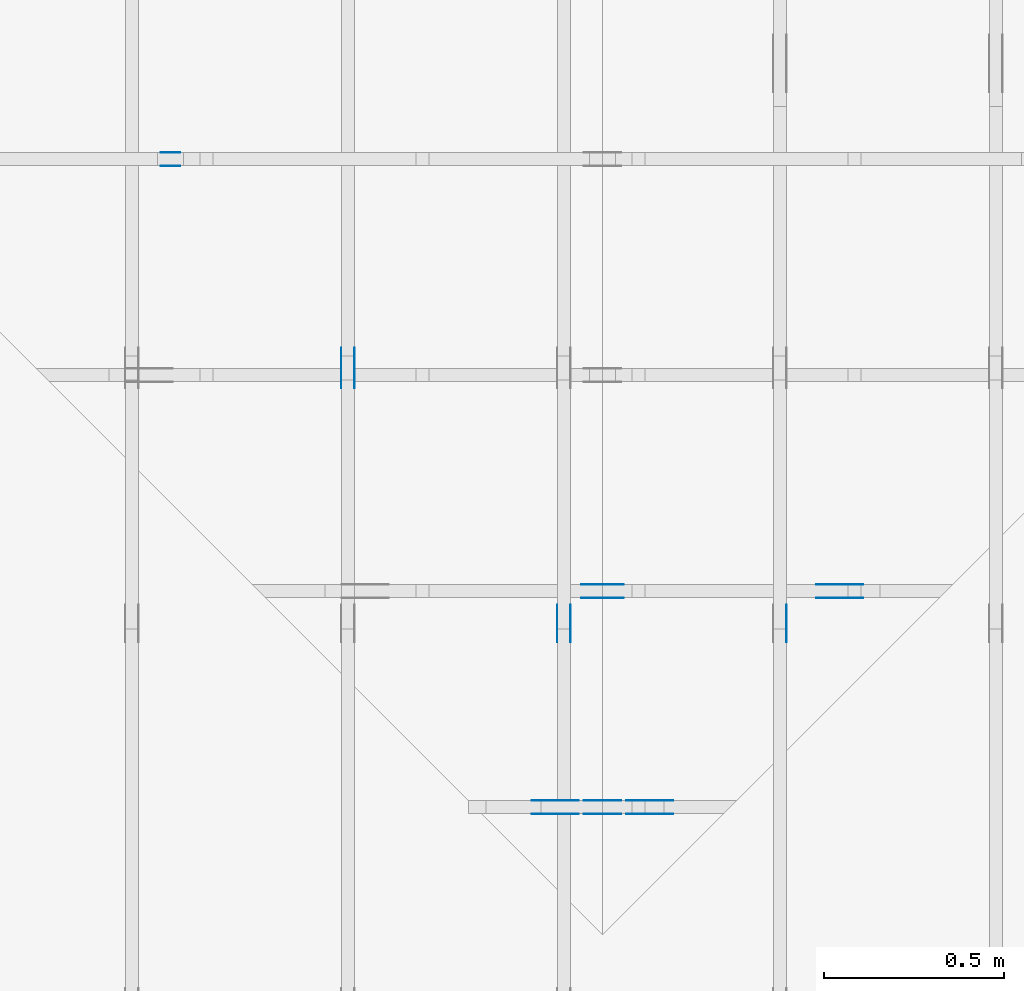
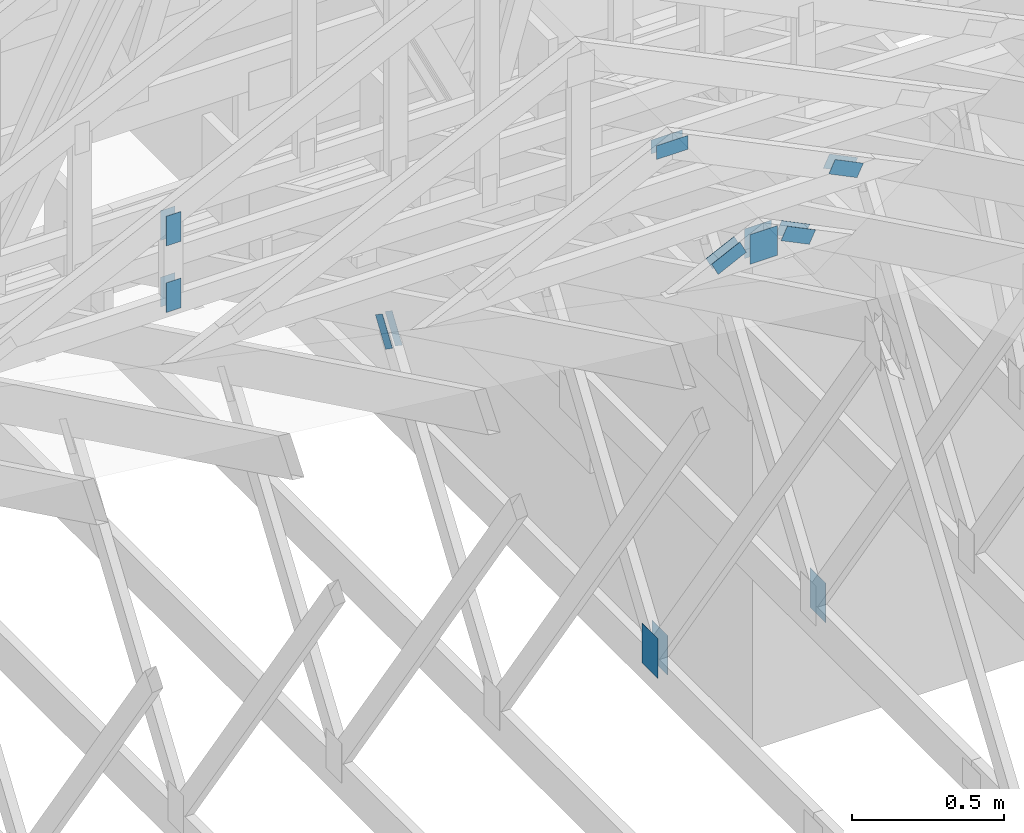
# One storey, part 87 of 159: 19 plates, 6 elements without a shape of their own.
"""IFC2X3 building model written with IfcOpenShell, lengths in millimetres."""

from ifc_helpers import new_model, si_unit, frame, origin, origin_with_axes, origin_2d, place, context, project, spatial, faceted_brep, element, aggregate, save


model = new_model("IFC2X3")

# Units and contexts
model_context = context("Model", 3, precision=1e-05, world=origin())
plan_context = context("Plan", 2, precision=1e-05, world=origin_2d())
ifc_project = project(units=[si_unit("LENGTHUNIT", "METRE", prefix="MILLI"), si_unit("AREAUNIT", "SQUARE_METRE"), si_unit("VOLUMEUNIT", "CUBIC_METRE"), si_unit("SOLIDANGLEUNIT", "STERADIAN"), si_unit("PLANEANGLEUNIT", "RADIAN"), si_unit("MASSUNIT", "GRAM"), si_unit("TIMEUNIT", "SECOND"), si_unit("THERMODYNAMICTEMPERATUREUNIT", "DEGREE_CELSIUS"), si_unit("LUMINOUSINTENSITYUNIT", "LUMEN")], contexts=[model_context, plan_context])

# Site, building, storey
site_placement = place(None, origin_with_axes())
site = spatial("IfcSite", under=ifc_project, at=site_placement, CompositionType="ELEMENT")
building_placement = place(site_placement, origin_with_axes())
building = spatial("IfcBuilding", under=site, at=building_placement, Name="Plan 1", CompositionType="ELEMENT")
storey_placement = place(building_placement, origin_with_axes())
storey = spatial("IfcBuildingStorey", under=building, at=storey_placement, Name="Etasje 1", CompositionType="ELEMENT", Elevation=0.0)

# Assembly, plate
assembly_1_placement = place(storey_placement, frame((15075.02226140475, -699.9989301294845, 1.1021457184401395e-15), z_axis=(-1.0, 1.836909530733566e-16, 6.123031769111886e-17), x_axis=(-1.836909530733566e-16, -1.0, 0.0)))
assembly_1 = element("IfcElementAssembly", 1, at=assembly_1_placement, inside=storey, Name="T7 (103)", AssemblyPlace="FACTORY", PredefinedType="TRUSS")
plate_1_placement = place(assembly_1_placement, frame((-6612.752711728468, 291.4999999999997, -37.0), z_axis=(0.0, 0.0, 1.0), x_axis=(6.123031769111886e-17, 1.0, 0.0)))
plate_1 = element("IfcPlate", 2, at=plate_1_placement, Name="GNT100S 103x159", context=model_context, shape_type="Brep", body=[
    faceted_brep([(159.00000000000028, 103.00021795903194, 1.0), (2.8421709430404007e-13, 103.00021795903194, 1.0), (2.8421709430404007e-13, 0.00021795903194288258, 1.0), (159.00000000000028, 0.00021795903194288258, 1.0), (2.8421709430404007e-13, 103.00021795903194, 3.4805405954966126e-29), (159.00000000000028, 103.00021795903194, 1.9471241025775833e-14), (159.00000000000028, 0.00021795903194288258, 1.9471241025775833e-14), (2.8421709430404007e-13, 0.00021795903194288258, 3.4805405954966126e-29), (159.0, -2.92068615386637e-14, 1.788345410772899e-30), (159.0, -2.914563122097258e-14, 1.0), (1.1247455413666031e-32, 6.123031769111886e-17, 1.0), (0.0, 0.0, 0.0), (159.0, 103.0, 0.0), (159.0, 103.0, 1.0), (159.0, 0.0, 1.0), (159.0, 0.0, 0.0), (0.0, 103.0, 0.0), (-3.7491518045553436e-33, 103.0, 1.0), (159.0, 102.99999999999999, 1.0), (159.0, 102.99999999999999, -7.888609052210118e-31), (0.0, 0.0, 0.0), (6.123031769111886e-17, -7.498303609110687e-33, 1.0), (1.2674675762061605e-14, 103.0, 1.0), (1.2613445444370486e-14, 103.0, -7.723252717384008e-31)], [[[0, 1, 2, 3]], [[4, 5, 6, 7]], [[8, 9, 10, 11]], [[12, 13, 14, 15]], [[16, 17, 18, 19]], [[20, 21, 22, 23]]]),
])
aggregate(assembly_1, [plate_1])

# Assembly, plates
assembly_2_placement = place(storey_placement, frame((14475.022261404752, -699.9989301294836, 1.1021457184401395e-15), z_axis=(-1.0, 1.836909530733566e-16, 6.123031769111886e-17), x_axis=(-1.836909530733566e-16, -1.0, 0.0)))
assembly_2 = element("IfcElementAssembly", 3, at=assembly_2_placement, inside=storey, Name="T10 (102)", AssemblyPlace="FACTORY", PredefinedType="TRUSS")
plate_2_placement = place(assembly_2_placement, frame((-6612.752711728468, 291.4999999999997, 0.0), z_axis=(0.0, 0.0, 1.0), x_axis=(6.123031769111886e-17, 1.0, 0.0)))
plate_2 = element("IfcPlate", 4, at=plate_2_placement, Name="GNT100S 103x159", context=model_context, shape_type="Brep", body=[
    faceted_brep([(159.00000000000028, 103.00021795903194, 1.0), (2.8421709430404007e-13, 103.00021795903194, 1.0), (2.8421709430404007e-13, 0.00021795903194288258, 1.0), (159.00000000000028, 0.00021795903194288258, 1.0), (2.8421709430404007e-13, 103.00021795903194, 3.4805405954966126e-29), (159.00000000000028, 103.00021795903194, 1.9471241025775833e-14), (159.00000000000028, 0.00021795903194288258, 1.9471241025775833e-14), (2.8421709430404007e-13, 0.00021795903194288258, 3.4805405954966126e-29), (159.0, -2.92068615386637e-14, 1.788345410772899e-30), (159.0, -2.914563122097258e-14, 1.0), (1.1247455413666031e-32, 6.123031769111886e-17, 1.0), (0.0, 0.0, 0.0), (159.0, 103.0, 0.0), (159.0, 103.0, 1.0), (159.0, 0.0, 1.0), (159.0, 0.0, 0.0), (0.0, 103.0, 0.0), (-3.7491518045553436e-33, 103.0, 1.0), (159.0, 102.99999999999999, 1.0), (159.0, 102.99999999999999, -7.888609052210118e-31), (0.0, 0.0, 0.0), (6.123031769111886e-17, -7.498303609110687e-33, 1.0), (1.2674675762061605e-14, 103.0, 1.0), (1.2613445444370486e-14, 103.0, -7.723252717384008e-31)], [[[0, 1, 2, 3]], [[4, 5, 6, 7]], [[8, 9, 10, 11]], [[12, 13, 14, 15]], [[16, 17, 18, 19]], [[20, 21, 22, 23]]]),
])
plate_3_placement = place(assembly_2_placement, frame((-6612.752711728468, 291.4999999999997, -37.0), z_axis=(0.0, 0.0, 1.0), x_axis=(6.123031769111886e-17, 1.0, 0.0)))
plate_3 = element("IfcPlate", 5, at=plate_3_placement, Name="GNT100S 103x159", context=model_context, shape_type="Brep", body=[
    faceted_brep([(159.00000000000028, 103.00021795903194, 1.0), (2.8421709430404007e-13, 103.00021795903194, 1.0), (2.8421709430404007e-13, 0.00021795903194288258, 1.0), (159.00000000000028, 0.00021795903194288258, 1.0), (2.8421709430404007e-13, 103.00021795903194, 3.4805405954966126e-29), (159.00000000000028, 103.00021795903194, 1.9471241025775833e-14), (159.00000000000028, 0.00021795903194288258, 1.9471241025775833e-14), (2.8421709430404007e-13, 0.00021795903194288258, 3.4805405954966126e-29), (159.0, -2.92068615386637e-14, 1.788345410772899e-30), (159.0, -2.914563122097258e-14, 1.0), (1.1247455413666031e-32, 6.123031769111886e-17, 1.0), (0.0, 0.0, 0.0), (159.0, 103.0, 0.0), (159.0, 103.0, 1.0), (159.0, 0.0, 1.0), (159.0, 0.0, 0.0), (0.0, 103.0, 0.0), (-3.7491518045553436e-33, 103.0, 1.0), (159.0, 102.99999999999999, 1.0), (159.0, 102.99999999999999, -7.888609052210118e-31), (0.0, 0.0, 0.0), (6.123031769111886e-17, -7.498303609110687e-33, 1.0), (1.2674675762061605e-14, 103.0, 1.0), (1.2613445444370486e-14, 103.0, -7.723252717384008e-31)], [[[0, 1, 2, 3]], [[4, 5, 6, 7]], [[8, 9, 10, 11]], [[12, 13, 14, 15]], [[16, 17, 18, 19]], [[20, 21, 22, 23]]]),
])
aggregate(assembly_2, [plate_2, plate_3])

assembly_3_placement = place(storey_placement, frame((13875.022261404752, -699.9989301294836, 1.1021457184401395e-15), z_axis=(-1.0, 1.836909530733566e-16, 6.123031769111886e-17), x_axis=(-1.836909530733566e-16, -1.0, 0.0)))
assembly_3 = element("IfcElementAssembly", 6, at=assembly_3_placement, inside=storey, Name="T6 (101)", AssemblyPlace="FACTORY", PredefinedType="TRUSS")
plate_4_placement = place(assembly_3_placement, frame((-7430.1562647054525, 1464.8788056966719, 0.0), z_axis=(0.0, 0.0, 1.0), x_axis=(0.56424750500642, -0.8256056886274646, 0.0)))
plate_4 = element("IfcPlate", 7, at=plate_4_placement, Name="GNT100S 55x119", context=model_context, shape_type="Brep", body=[
    faceted_brep([(119.00002539657544, 54.99988487959854, 1.0), (0.0, 54.99988487959854, 1.0), (2.606205816846341e-05, 0.0, 1.0), (119.0000514586336, 0.0, 1.0), (0.0, 54.99988487959854, 0.0), (119.00002539657544, 54.99988487959854, 1.4572818720567054e-14), (119.0000514586336, 4.891776097792899e-05, 1.4572821912143256e-14), (2.606205816846341e-05, 4.891776097792899e-05, 3.191576202678868e-21), (119.0000637359608, 2.5329963114896162e-05, 1.3384479605016376e-30), (119.0000637359608, 2.5329963114957392e-05, 1.0), (6.373596079356503e-05, 2.5329963136816616e-05, 1.0), (6.373596079356503e-05, 2.5329963136755386e-05, 7.52316384526264e-37), (119.0000637359608, 55.00002532996314, 0.0), (119.0000637359608, 55.00002532996314, 1.0), (119.0000637359608, 2.5329963136755396e-05, 1.0), (119.0000637359608, 2.5329963136755396e-05, 0.0), (6.373596079356503e-05, 55.000025329964046, 0.0), (6.373596079356503e-05, 55.000025329964046, 1.0), (119.0000637359608, 55.000025329963165, 1.0), (119.0000637359608, 55.000025329963165, 2.3665827156630354e-30), (6.373596079356503e-05, 2.5329963136755396e-05, 0.0), (6.373596079362626e-05, 2.5329963136755396e-05, 1.0), (6.373596080036159e-05, 55.000025329964046, 1.0), (6.373596080030036e-05, 55.000025329964046, -4.12407052618761e-31)], [[[0, 1, 2, 3]], [[4, 5, 6, 7]], [[8, 9, 10, 11]], [[12, 13, 14, 15]], [[16, 17, 18, 19]], [[20, 21, 22, 23]]]),
])
plate_5_placement = place(assembly_3_placement, frame((-7430.1562647054525, 1464.8788056966719, -37.0), z_axis=(0.0, 0.0, 1.0), x_axis=(0.56424750500642, -0.8256056886274646, 0.0)))
plate_5 = element("IfcPlate", 8, at=plate_5_placement, Name="GNT100S 55x119", context=model_context, shape_type="Brep", body=[
    faceted_brep([(119.00002539657544, 54.99988487959854, 1.0), (0.0, 54.99988487959854, 1.0), (2.606205816846341e-05, 0.0, 1.0), (119.0000514586336, 0.0, 1.0), (0.0, 54.99988487959854, 0.0), (119.00002539657544, 54.99988487959854, 1.4572818720567054e-14), (119.0000514586336, 4.891776097792899e-05, 1.4572821912143256e-14), (2.606205816846341e-05, 4.891776097792899e-05, 3.191576202678868e-21), (119.0000637359608, 2.5329963114896162e-05, 1.3384479605016376e-30), (119.0000637359608, 2.5329963114957392e-05, 1.0), (6.373596079356503e-05, 2.5329963136816616e-05, 1.0), (6.373596079356503e-05, 2.5329963136755386e-05, 7.52316384526264e-37), (119.0000637359608, 55.00002532996314, 0.0), (119.0000637359608, 55.00002532996314, 1.0), (119.0000637359608, 2.5329963136755396e-05, 1.0), (119.0000637359608, 2.5329963136755396e-05, 0.0), (6.373596079356503e-05, 55.000025329964046, 0.0), (6.373596079356503e-05, 55.000025329964046, 1.0), (119.0000637359608, 55.000025329963165, 1.0), (119.0000637359608, 55.000025329963165, 2.3665827156630354e-30), (6.373596079356503e-05, 2.5329963136755396e-05, 0.0), (6.373596079362626e-05, 2.5329963136755396e-05, 1.0), (6.373596080036159e-05, 55.000025329964046, 1.0), (6.373596080030036e-05, 55.000025329964046, -4.12407052618761e-31)], [[[0, 1, 2, 3]], [[4, 5, 6, 7]], [[8, 9, 10, 11]], [[12, 13, 14, 15]], [[16, 17, 18, 19]], [[20, 21, 22, 23]]]),
])
aggregate(assembly_3, [plate_4, plate_5])

assembly_4_placement = place(storey_placement, frame((12446.012607049342, 7236.0000560521385, 1312.9938842936408), z_axis=(0.0, -1.0, 6.123031769111886e-17), x_axis=(1.0, 0.0, 0.0)))
assembly_4 = element("IfcElementAssembly", 9, at=assembly_4_placement, inside=storey, Name="Tr3 (84)", AssemblyPlace="FACTORY", PredefinedType="TRUSS")
plate_6_placement = place(assembly_4_placement, frame((926.5000560521408, 415.7619323730469, 0.0), z_axis=(0.0, 0.0, 1.0), x_axis=(6.123031769111886e-17, -1.0, 0.0)))
plate_6 = element("IfcPlate", 10, at=plate_6_placement, Name="GNT100S 55x119", context=model_context, shape_type="Brep", body=[
    faceted_brep([(119.0, 55.0000049830154, 1.0), (0.0, 55.0000049830154, 1.0), (0.0, 4.9830154011942795e-06, 1.0), (119.0, 4.9830154011942795e-06, 1.0), (0.0, 55.0000049830154, 0.0), (119.0, 55.0000049830154, 1.457281561048629e-14), (119.0, 4.9830154011942795e-06, 1.457281561048629e-14), (0.0, 4.9830154011942795e-06, 0.0), (119.0000057091192, -2.185922446444298e-14, 1.3384472584393212e-30), (119.0000057091192, -2.179799414675186e-14, 1.0), (5.7091191933977825e-06, 6.122926897757302e-17, 1.0), (5.7091191933977825e-06, -1.0487135458446315e-21, 6.421306357904653e-38), (119.0000057091192, 55.0, 0.0), (119.0000057091192, 55.0, 1.0), (119.0000057091192, 0.0, 1.0), (119.0000057091192, 0.0, 0.0), (5.7091191933977825e-06, 55.0, 0.0), (5.7091191933977825e-06, 55.0, 1.0), (119.0000057091192, 54.99999999999999, 1.0), (119.0000057091192, 54.99999999999999, -3.944304526105059e-31), (5.7091191933977825e-06, 0.0, 0.0), (5.709119193459013e-06, -7.498303609110687e-33, 1.0), (5.709119200194348e-06, 55.0, 1.0), (5.7091192001331175e-06, 55.0, -4.124066764605687e-31)], [[[0, 1, 2, 3]], [[4, 5, 6, 7]], [[8, 9, 10, 11]], [[12, 13, 14, 15]], [[16, 17, 18, 19]], [[20, 21, 22, 23]]]),
])
plate_7_placement = place(assembly_4_placement, frame((926.5000560521408, 415.7619323730469, -37.0), z_axis=(0.0, 0.0, 1.0), x_axis=(6.123031769111886e-17, -1.0, 0.0)))
plate_7 = element("IfcPlate", 11, at=plate_7_placement, Name="GNT100S 55x119", context=model_context, shape_type="Brep", body=[
    faceted_brep([(119.0, 55.0000049830154, 1.0), (0.0, 55.0000049830154, 1.0), (0.0, 4.9830154011942795e-06, 1.0), (119.0, 4.9830154011942795e-06, 1.0), (0.0, 55.0000049830154, 0.0), (119.0, 55.0000049830154, 1.457281561048629e-14), (119.0, 4.9830154011942795e-06, 1.457281561048629e-14), (0.0, 4.9830154011942795e-06, 0.0), (119.0000057091192, -2.185922446444298e-14, 1.3384472584393212e-30), (119.0000057091192, -2.179799414675186e-14, 1.0), (5.7091191933977825e-06, 6.122926897757302e-17, 1.0), (5.7091191933977825e-06, -1.0487135458446315e-21, 6.421306357904653e-38), (119.0000057091192, 55.0, 0.0), (119.0000057091192, 55.0, 1.0), (119.0000057091192, 0.0, 1.0), (119.0000057091192, 0.0, 0.0), (5.7091191933977825e-06, 55.0, 0.0), (5.7091191933977825e-06, 55.0, 1.0), (119.0000057091192, 54.99999999999999, 1.0), (119.0000057091192, 54.99999999999999, -3.944304526105059e-31), (5.7091191933977825e-06, 0.0, 0.0), (5.709119193459013e-06, -7.498303609110687e-33, 1.0), (5.709119200194348e-06, 55.0, 1.0), (5.7091192001331175e-06, 55.0, -4.124066764605687e-31)], [[[0, 1, 2, 3]], [[4, 5, 6, 7]], [[8, 9, 10, 11]], [[12, 13, 14, 15]], [[16, 17, 18, 19]], [[20, 21, 22, 23]]]),
])
plate_8_placement = place(assembly_4_placement, frame((981.5000610351562, 29.720829010009762, 0.0), z_axis=(0.0, 0.0, 1.0), x_axis=(6.123031769111886e-17, 1.0, 0.0)))
plate_8 = element("IfcPlate", 12, at=plate_8_placement, Name="GNT100S 55x119", context=model_context, shape_type="Brep", body=[
    faceted_brep([(118.99999618530273, 55.0, 1.0), (0.0, 55.0, 1.0), (3.552713678800501e-15, 0.0, 1.0), (118.99999618530273, 0.0, 1.0), (0.0, 55.0, 0.0), (118.99999618530273, 55.0, 1.457281514333604e-14), (118.99999618530273, 0.0, 1.457281514333604e-14), (3.552713678800501e-15, 0.0, 4.350675744370766e-31), (119.0000000204891, 4.983015265648218e-06, 1.338447208185253e-30), (119.0000000204891, 4.983015265709449e-06, 1.0), (2.0489100194254206e-08, 4.983015287568672e-06, 1.0), (2.0489100194254206e-08, 4.983015287507442e-06, 0.0), (119.0000000204891, 55.00000498301529, 0.0), (119.0000000204891, 55.00000498301529, 1.0), (119.0000000204891, 4.983015287507442e-06, 1.0), (119.0000000204891, 4.983015287507442e-06, 0.0), (2.0489100194254206e-08, 55.00000498301529, 0.0), (2.0489100194254206e-08, 55.00000498301529, 1.0), (119.0000000204891, 55.00000498301528, 1.0), (119.0000000204891, 55.00000498301528, -3.944304526105059e-31), (2.0489100194254815e-08, 4.983015287507442e-06, -3.728521144014443e-38), (2.0489100255485133e-08, 4.983015287507442e-06, 1.0), (2.048910699082008e-08, 55.00000498301529, 1.0), (2.048910692958976e-08, 55.00000498301529, -4.124067357862992e-31)], [[[0, 1, 2, 3]], [[4, 5, 6, 7]], [[8, 9, 10, 11]], [[12, 13, 14, 15]], [[16, 17, 18, 19]], [[20, 21, 22, 23]]]),
])
plate_9_placement = place(assembly_4_placement, frame((981.5000610351562, 29.720829010009762, -37.0), z_axis=(0.0, 0.0, 1.0), x_axis=(6.123031769111886e-17, 1.0, 0.0)))
plate_9 = element("IfcPlate", 13, at=plate_9_placement, Name="GNT100S 55x119", context=model_context, shape_type="Brep", body=[
    faceted_brep([(118.99999618530273, 55.0, 1.0), (0.0, 55.0, 1.0), (3.552713678800501e-15, 0.0, 1.0), (118.99999618530273, 0.0, 1.0), (0.0, 55.0, 0.0), (118.99999618530273, 55.0, 1.457281514333604e-14), (118.99999618530273, 0.0, 1.457281514333604e-14), (3.552713678800501e-15, 0.0, 4.350675744370766e-31), (119.0000000204891, 4.983015265648218e-06, 1.338447208185253e-30), (119.0000000204891, 4.983015265709449e-06, 1.0), (2.0489100194254206e-08, 4.983015287568672e-06, 1.0), (2.0489100194254206e-08, 4.983015287507442e-06, 0.0), (119.0000000204891, 55.00000498301529, 0.0), (119.0000000204891, 55.00000498301529, 1.0), (119.0000000204891, 4.983015287507442e-06, 1.0), (119.0000000204891, 4.983015287507442e-06, 0.0), (2.0489100194254206e-08, 55.00000498301529, 0.0), (2.0489100194254206e-08, 55.00000498301529, 1.0), (119.0000000204891, 55.00000498301528, 1.0), (119.0000000204891, 55.00000498301528, -3.944304526105059e-31), (2.0489100194254815e-08, 4.983015287507442e-06, -3.728521144014443e-38), (2.0489100255485133e-08, 4.983015287507442e-06, 1.0), (2.048910699082008e-08, 55.00000498301529, 1.0), (2.048910692958976e-08, 55.00000498301529, -4.124067357862992e-31)], [[[0, 1, 2, 3]], [[4, 5, 6, 7]], [[8, 9, 10, 11]], [[12, 13, 14, 15]], [[16, 17, 18, 19]], [[20, 21, 22, 23]]]),
])
aggregate(assembly_4, [plate_6, plate_7, plate_8, plate_9])

assembly_5_placement = place(storey_placement, frame((13646.012618823253, 6036.0000442782275, 1898.2729963151946), z_axis=(0.0, -1.0, 6.123031769111886e-17), x_axis=(1.0, 0.0, 0.0)))
assembly_5 = element("IfcElementAssembly", 14, at=assembly_5_placement, inside=storey, Name="Tr5 (109)", AssemblyPlace="FACTORY", PredefinedType="TRUSS")
plate_10_placement = place(assembly_5_placement, frame((894.5000442782296, 377.1683044433594, 0.0), z_axis=(0.0, 0.0, 1.0), x_axis=(1.0, 0.0, 0.0)))
plate_10 = element("IfcPlate", 15, at=plate_10_placement, Name="GNT100S 55x119", context=model_context, shape_type="Brep", body=[
    faceted_brep([(119.0000167569267, 55.0, 1.0), (1.6756926697780727e-05, 55.0, 1.0), (1.6756926697780727e-05, 0.0, 1.0), (119.0000167569267, 0.0, 1.0), (1.6756926697780727e-05, 55.0, 2.0520638904638105e-21), (119.0000167569267, 55.0, 1.457281766255018e-14), (119.0000167569267, 0.0, 1.457281766255018e-14), (1.6756926697780727e-05, 0.0, 2.0520638904638105e-21), (119.0, 4.4972532665772604e-07, 1.3384471964303096e-30), (119.0, 4.4972532671895635e-07, 1.0), (1.1247455413666031e-32, 4.4972534857817977e-07, 1.0), (0.0, 4.4972534851694945e-07, 0.0), (119.0, 55.00000044972535, 0.0), (119.0, 55.00000044972535, 1.0), (119.0, 4.4972534851694945e-07, 1.0), (119.0, 4.4972534851694945e-07, 0.0), (0.0, 55.00000044972535, 0.0), (-3.7491518045553436e-33, 55.00000044972535, 1.0), (119.0, 55.00000044972534, 1.0), (119.0, 55.00000044972534, -3.944304526105059e-31), (5.507365192688393e-23, 4.4972534851694945e-07, -3.372177203893204e-39), (6.123037276477079e-17, 4.4972534851694945e-07, 1.0), (6.796565318787846e-15, 55.00000044972535, 1.0), (6.735335001096727e-15, 55.00000044972535, -4.12406701873265e-31)], [[[0, 1, 2, 3]], [[4, 5, 6, 7]], [[8, 9, 10, 11]], [[12, 13, 14, 15]], [[16, 17, 18, 19]], [[20, 21, 22, 23]]]),
])
plate_11_placement = place(assembly_5_placement, frame((894.5000442782296, 377.1683044433594, -37.0), z_axis=(0.0, 0.0, 1.0), x_axis=(1.0, 0.0, 0.0)))
plate_11 = element("IfcPlate", 16, at=plate_11_placement, Name="GNT100S 55x119", context=model_context, shape_type="Brep", body=[
    faceted_brep([(119.0000167569267, 55.0, 1.0), (1.6756926697780727e-05, 55.0, 1.0), (1.6756926697780727e-05, 0.0, 1.0), (119.0000167569267, 0.0, 1.0), (1.6756926697780727e-05, 55.0, 2.0520638904638105e-21), (119.0000167569267, 55.0, 1.457281766255018e-14), (119.0000167569267, 0.0, 1.457281766255018e-14), (1.6756926697780727e-05, 0.0, 2.0520638904638105e-21), (119.0, 4.4972532665772604e-07, 1.3384471964303096e-30), (119.0, 4.4972532671895635e-07, 1.0), (1.1247455413666031e-32, 4.4972534857817977e-07, 1.0), (0.0, 4.4972534851694945e-07, 0.0), (119.0, 55.00000044972535, 0.0), (119.0, 55.00000044972535, 1.0), (119.0, 4.4972534851694945e-07, 1.0), (119.0, 4.4972534851694945e-07, 0.0), (0.0, 55.00000044972535, 0.0), (-3.7491518045553436e-33, 55.00000044972535, 1.0), (119.0, 55.00000044972534, 1.0), (119.0, 55.00000044972534, -3.944304526105059e-31), (5.507365192688393e-23, 4.4972534851694945e-07, -3.372177203893204e-39), (6.123037276477079e-17, 4.4972534851694945e-07, 1.0), (6.796565318787846e-15, 55.00000044972535, 1.0), (6.735335001096727e-15, 55.00000044972535, -4.12406701873265e-31)], [[[0, 1, 2, 3]], [[4, 5, 6, 7]], [[8, 9, 10, 11]], [[12, 13, 14, 15]], [[16, 17, 18, 19]], [[20, 21, 22, 23]]]),
])
plate_12_placement = place(assembly_5_placement, frame((1678.8263451835883, 87.85456136604694, 0.0), z_axis=(0.0, 0.0, 1.0), x_axis=(-0.8987940462991675, 0.4383711467890765, 0.0)))
plate_12 = element("IfcPlate", 17, at=plate_12_placement, Name="GNT100S 55x119", context=model_context, shape_type="Brep", body=[
    faceted_brep([(119.00004534387699, 54.999976566378905, 1.0), (0.0, 54.999976566378905, 1.0), (5.586085535469465e-05, 2.3515951852459693e-06, 1.0), (119.0001028769857, 2.3515951852459693e-06, 1.0), (0.0, 54.999976566378905, 0.0), (119.00004534387699, 54.999976566378905, 1.4572821163326278e-14), (119.0001028769857, 2.334141424853442e-05, 1.4572828208867324e-14), (5.586085535469465e-05, 2.334141424853442e-05, 6.840755839731183e-21), (119.00004722772155, -2.1859232091034618e-14, 1.3384477254179502e-30), (119.00004722772155, -2.17980017733435e-14, 1.0), (4.7227721552189905e-05, 6.122164238593546e-17, 1.0), (4.7227721552189905e-05, -8.675305183404867e-21, 5.311916924472902e-37), (119.00004722772155, 55.000000000000114, 0.0), (119.00004722772155, 55.000000000000114, 1.0), (119.00004722772155, 0.0, 1.0), (119.00004722772155, 0.0, 0.0), (4.7227721552189905e-05, 55.0, 0.0), (4.7227721552189905e-05, 55.0, 1.0), (119.00004722772155, 55.00000000000013, 1.0), (119.00004722772155, 55.00000000000013, 3.944304526105059e-31), (4.7227721552189905e-05, 0.0, 0.0), (4.7227721552251136e-05, -7.498303609110687e-33, 1.0), (4.722772155898647e-05, 55.0, 1.0), (4.722772155892524e-05, 55.0, -4.124066764605687e-31)], [[[0, 1, 2, 3]], [[4, 5, 6, 7]], [[8, 9, 10, 11]], [[12, 13, 14, 15]], [[16, 17, 18, 19]], [[20, 21, 22, 23]]]),
])
plate_13_placement = place(assembly_5_placement, frame((1678.8263451835883, 87.85456136604694, -37.0), z_axis=(0.0, 0.0, 1.0), x_axis=(-0.8987940462991675, 0.4383711467890765, 0.0)))
plate_13 = element("IfcPlate", 18, at=plate_13_placement, Name="GNT100S 55x119", context=model_context, shape_type="Brep", body=[
    faceted_brep([(119.00004534387699, 54.999976566378905, 1.0), (0.0, 54.999976566378905, 1.0), (5.586085535469465e-05, 2.3515951852459693e-06, 1.0), (119.0001028769857, 2.3515951852459693e-06, 1.0), (0.0, 54.999976566378905, 0.0), (119.00004534387699, 54.999976566378905, 1.4572821163326278e-14), (119.0001028769857, 2.334141424853442e-05, 1.4572828208867324e-14), (5.586085535469465e-05, 2.334141424853442e-05, 6.840755839731183e-21), (119.00004722772155, -2.1859232091034618e-14, 1.3384477254179502e-30), (119.00004722772155, -2.17980017733435e-14, 1.0), (4.7227721552189905e-05, 6.122164238593546e-17, 1.0), (4.7227721552189905e-05, -8.675305183404867e-21, 5.311916924472902e-37), (119.00004722772155, 55.000000000000114, 0.0), (119.00004722772155, 55.000000000000114, 1.0), (119.00004722772155, 0.0, 1.0), (119.00004722772155, 0.0, 0.0), (4.7227721552189905e-05, 55.0, 0.0), (4.7227721552189905e-05, 55.0, 1.0), (119.00004722772155, 55.00000000000013, 1.0), (119.00004722772155, 55.00000000000013, 3.944304526105059e-31), (4.7227721552189905e-05, 0.0, 0.0), (4.7227721552251136e-05, -7.498303609110687e-33, 1.0), (4.722772155898647e-05, 55.0, 1.0), (4.722772155892524e-05, 55.0, -4.124066764605687e-31)], [[[0, 1, 2, 3]], [[4, 5, 6, 7]], [[8, 9, 10, 11]], [[12, 13, 14, 15]], [[16, 17, 18, 19]], [[20, 21, 22, 23]]]),
])
aggregate(assembly_5, [plate_10, plate_11, plate_12, plate_13])

assembly_6_placement = place(storey_placement, frame((14246.012624710209, 5436.000038391272, 2190.9125523259713), z_axis=(0.0, -1.0, 6.123031769111886e-17), x_axis=(1.0, 0.0, 0.0)))
assembly_6 = element("IfcElementAssembly", 19, at=assembly_6_placement, inside=storey, Name="Tr6 (110)", AssemblyPlace="FACTORY", PredefinedType="TRUSS")
plate_14_placement = place(assembly_6_placement, frame((181.15270528760757, 26.796075448936165, 0.0), z_axis=(0.0, 0.0, 1.0), x_axis=(0.8987940463005369, 0.4383711467862691, 0.0)))
plate_14 = element("IfcPlate", 20, at=plate_14_placement, Name="GNT100S 55x119", context=model_context, shape_type="Brep", body=[
    faceted_brep([(118.99999836029991, 55.00000097083511, 1.0), (6.2022046449783375e-06, 55.00000097083511, 1.0), (5.199555999979566e-06, 0.0, 1.0), (118.999995685398, 0.0, 1.0), (6.2022046449783375e-06, 55.00000097083511, 7.595259215947134e-22), (118.99999836029991, 55.00000097083511, 1.4572815409687574e-14), (118.999995685398, 2.337976859223545e-06, 1.4572815082117387e-14), (5.199555999979566e-06, 2.337976859223545e-06, 6.367409314630241e-22), (119.0, 2.1370154280730546e-06, 1.338447184675366e-30), (119.0, 2.137015428134285e-06, 1.0), (1.1247455413666031e-32, 2.1370154499935083e-06, 1.0), (0.0, 2.137015449932278e-06, 0.0), (119.0, 55.00000213701545, 0.0), (119.0, 55.00000213701545, 1.0), (119.0, 2.137015449932278e-06, 1.0), (119.0, 2.137015449932278e-06, 0.0), (0.0, 55.000002137015436, 0.0), (0.0, 55.000002137015436, 1.0), (119.00000000000001, 55.00000213701546, 1.0), (119.00000000000001, 55.00000213701546, 3.944304526105059e-31), (2.617002698203654e-22, 2.137015449932278e-06, -1.60239906609525e-38), (6.123057939138869e-17, 2.137015449932278e-06, 1.0), (6.796565525414462e-15, 55.000002137015436, 1.0), (6.735335207723343e-15, 55.000002137015436, -4.124067145250783e-31)], [[[0, 1, 2, 3]], [[4, 5, 6, 7]], [[8, 9, 10, 11]], [[12, 13, 14, 15]], [[16, 17, 18, 19]], [[20, 21, 22, 23]]]),
])
plate_15_placement = place(assembly_6_placement, frame((181.15270528760757, 26.796075448936165, -37.00000000000001), z_axis=(0.0, 0.0, 1.0), x_axis=(0.8987940463005369, 0.4383711467862691, 0.0)))
plate_15 = element("IfcPlate", 21, at=plate_15_placement, Name="GNT100S 55x119", context=model_context, shape_type="Brep", body=[
    faceted_brep([(118.99999836029991, 55.00000097083511, 1.0), (6.2022046449783375e-06, 55.00000097083511, 1.0), (5.199555999979566e-06, 0.0, 1.0), (118.999995685398, 0.0, 1.0), (6.2022046449783375e-06, 55.00000097083511, 7.595259215947134e-22), (118.99999836029991, 55.00000097083511, 1.4572815409687574e-14), (118.999995685398, 2.337976859223545e-06, 1.4572815082117387e-14), (5.199555999979566e-06, 2.337976859223545e-06, 6.367409314630241e-22), (119.0, 2.1370154280730546e-06, 1.338447184675366e-30), (119.0, 2.137015428134285e-06, 1.0), (1.1247455413666031e-32, 2.1370154499935083e-06, 1.0), (0.0, 2.137015449932278e-06, 0.0), (119.0, 55.00000213701545, 0.0), (119.0, 55.00000213701545, 1.0), (119.0, 2.137015449932278e-06, 1.0), (119.0, 2.137015449932278e-06, 0.0), (0.0, 55.000002137015436, 0.0), (0.0, 55.000002137015436, 1.0), (119.00000000000001, 55.00000213701546, 1.0), (119.00000000000001, 55.00000213701546, 3.944304526105059e-31), (2.617002698203654e-22, 2.137015449932278e-06, -1.60239906609525e-38), (6.123057939138869e-17, 2.137015449932278e-06, 1.0), (6.796565525414462e-15, 55.000002137015436, 1.0), (6.735335207723343e-15, 55.000002137015436, -4.124067145250783e-31)], [[[0, 1, 2, 3]], [[4, 5, 6, 7]], [[8, 9, 10, 11]], [[12, 13, 14, 15]], [[16, 17, 18, 19]], [[20, 21, 22, 23]]]),
])
plate_16_placement = place(assembly_6_placement, frame((550.9577855049894, 76.22974991611332, 0.0), z_axis=(0.0, 0.0, 1.0), x_axis=(-0.8987940462999411, 0.4383711467874903, 0.0)))
plate_16 = element("IfcPlate", 22, at=plate_16_placement, Name="GNT100S 55x119", context=model_context, shape_type="Brep", body=[
    faceted_brep([(119.00000983902271, 55.000009040136746, 1.0), (1.935318067580738e-05, 55.000009040136746, 1.0), (2.0355904041480244e-05, 8.069301600244216e-06, 1.0), (119.00001251399937, 8.069301600244216e-06, 1.0), (1.935318067580738e-05, 55.000009040136746, 2.3700028022266166e-21), (119.00000983902271, 55.000009040136746, 1.4572816815379262e-14), (119.00001251399937, 2.3028592295304406e-06, 1.4572817142958603e-14), (2.0355904041480244e-05, 2.3028592295304406e-06, 2.4927969426995315e-21), (119.00000000000006, -2.1859223415729444e-14, 1.3384471942262584e-30), (119.00000000000006, -2.1797993098038325e-14, 1.0), (5.684341886080802e-14, 6.123031769110842e-17, 1.0), (5.684341886080802e-14, -1.0441621786489838e-29, 6.393438191972809e-46), (119.00000000000006, 54.99999999999994, 0.0), (119.00000000000006, 54.99999999999994, 1.0), (119.00000000000006, 0.0, 1.0), (119.00000000000006, 0.0, 0.0), (0.0, 54.99999999999997, 0.0), (0.0, 54.99999999999997, 1.0), (119.00000000000006, 54.999999999999936, 1.0), (119.00000000000006, 54.999999999999936, 0.0), (5.684341886080802e-14, 0.0, 0.0), (5.690464917849913e-14, 4.6885143195523885e-32, 1.0), (1.479017104101534e-14, 54.99999999999997, 1.0), (1.472894072332422e-14, 54.99999999999997, -9.018577197428003e-31)], [[[0, 1, 2, 3]], [[4, 5, 6, 7]], [[8, 9, 10, 11]], [[12, 13, 14, 15]], [[16, 17, 18, 19]], [[20, 21, 22, 23]]]),
])
plate_17_placement = place(assembly_6_placement, frame((550.9577855049894, 76.22974991611332, -37.0), z_axis=(0.0, 0.0, 1.0), x_axis=(-0.8987940462999411, 0.4383711467874903, 0.0)))
plate_17 = element("IfcPlate", 23, at=plate_17_placement, Name="GNT100S 55x119", context=model_context, shape_type="Brep", body=[
    faceted_brep([(119.00000983902271, 55.000009040136746, 1.0), (1.935318067580738e-05, 55.000009040136746, 1.0), (2.0355904041480244e-05, 8.069301600244216e-06, 1.0), (119.00001251399937, 8.069301600244216e-06, 1.0), (1.935318067580738e-05, 55.000009040136746, 2.3700028022266166e-21), (119.00000983902271, 55.000009040136746, 1.4572816815379262e-14), (119.00001251399937, 2.3028592295304406e-06, 1.4572817142958603e-14), (2.0355904041480244e-05, 2.3028592295304406e-06, 2.4927969426995315e-21), (119.00000000000006, -2.1859223415729444e-14, 1.3384471942262584e-30), (119.00000000000006, -2.1797993098038325e-14, 1.0), (5.684341886080802e-14, 6.123031769110842e-17, 1.0), (5.684341886080802e-14, -1.0441621786489838e-29, 6.393438191972809e-46), (119.00000000000006, 54.99999999999994, 0.0), (119.00000000000006, 54.99999999999994, 1.0), (119.00000000000006, 0.0, 1.0), (119.00000000000006, 0.0, 0.0), (0.0, 54.99999999999997, 0.0), (0.0, 54.99999999999997, 1.0), (119.00000000000006, 54.999999999999936, 1.0), (119.00000000000006, 54.999999999999936, 0.0), (5.684341886080802e-14, 0.0, 0.0), (5.690464917849913e-14, 4.6885143195523885e-32, 1.0), (1.479017104101534e-14, 54.99999999999997, 1.0), (1.472894072332422e-14, 54.99999999999997, -9.018577197428003e-31)], [[[0, 1, 2, 3]], [[4, 5, 6, 7]], [[8, 9, 10, 11]], [[12, 13, 14, 15]], [[16, 17, 18, 19]], [[20, 21, 22, 23]]]),
])
plate_18_placement = place(assembly_6_placement, frame((405.5000383912367, 25.043923492973814, 0.0), z_axis=(0.0, 0.0, 1.0), x_axis=(6.123031769111886e-17, 1.0, 0.0)))
plate_18 = element("IfcPlate", 24, at=plate_18_placement, Name="GNT100S 103x119", context=model_context, shape_type="Brep", body=[
    faceted_brep([(119.00000656073712, 103.0000078736586, 1.0), (8.386912178082184e-07, 103.0000078736586, 1.0), (8.386912249136458e-07, 7.873658603330114e-06, 1.0), (119.00000656073712, 7.873658603330114e-06, 1.0), (8.386912178082184e-07, 103.0000078736586, 1.0270665942229716e-22), (119.00000656073712, 103.0000078736586, 1.4572816413918326e-14), (119.00000656073712, 7.873658603330114e-06, 1.4572816413918326e-14), (8.386912249136458e-07, 7.873658603330114e-06, 1.0270666029243231e-22), (119.0, -2.1859223415729434e-14, 1.3384471942262577e-30), (119.0, -2.1797993098038315e-14, 1.0), (1.1247455413666031e-32, 6.123031769111886e-17, 1.0), (0.0, 0.0, 0.0), (119.0, 103.0, 0.0), (119.0, 103.0, 1.0), (119.0, 0.0, 1.0), (119.0, 0.0, 0.0), (0.0, 103.0, 0.0), (-3.7491518045553436e-33, 103.0, 1.0), (119.0, 102.99999999999999, 1.0), (119.0, 102.99999999999999, -7.888609052210118e-31), (0.0, 0.0, 0.0), (6.123031769111886e-17, -7.498303609110687e-33, 1.0), (1.2674675762061605e-14, 103.0, 1.0), (1.2613445444370486e-14, 103.0, -7.723252717384008e-31)], [[[0, 1, 2, 3]], [[4, 5, 6, 7]], [[8, 9, 10, 11]], [[12, 13, 14, 15]], [[16, 17, 18, 19]], [[20, 21, 22, 23]]]),
])
plate_19_placement = place(assembly_6_placement, frame((405.5000383912367, 25.043923492973814, -37.0), z_axis=(0.0, 0.0, 1.0), x_axis=(6.123031769111886e-17, 1.0, 0.0)))
plate_19 = element("IfcPlate", 25, at=plate_19_placement, Name="GNT100S 103x119", context=model_context, shape_type="Brep", body=[
    faceted_brep([(119.00000656073712, 103.0000078736586, 1.0), (8.386912178082184e-07, 103.0000078736586, 1.0), (8.386912249136458e-07, 7.873658603330114e-06, 1.0), (119.00000656073712, 7.873658603330114e-06, 1.0), (8.386912178082184e-07, 103.0000078736586, 1.0270665942229716e-22), (119.00000656073712, 103.0000078736586, 1.4572816413918326e-14), (119.00000656073712, 7.873658603330114e-06, 1.4572816413918326e-14), (8.386912249136458e-07, 7.873658603330114e-06, 1.0270666029243231e-22), (119.0, -2.1859223415729434e-14, 1.3384471942262577e-30), (119.0, -2.1797993098038315e-14, 1.0), (1.1247455413666031e-32, 6.123031769111886e-17, 1.0), (0.0, 0.0, 0.0), (119.0, 103.0, 0.0), (119.0, 103.0, 1.0), (119.0, 0.0, 1.0), (119.0, 0.0, 0.0), (0.0, 103.0, 0.0), (-3.7491518045553436e-33, 103.0, 1.0), (119.0, 102.99999999999999, 1.0), (119.0, 102.99999999999999, -7.888609052210118e-31), (0.0, 0.0, 0.0), (6.123031769111886e-17, -7.498303609110687e-33, 1.0), (1.2674675762061605e-14, 103.0, 1.0), (1.2613445444370486e-14, 103.0, -7.723252717384008e-31)], [[[0, 1, 2, 3]], [[4, 5, 6, 7]], [[8, 9, 10, 11]], [[12, 13, 14, 15]], [[16, 17, 18, 19]], [[20, 21, 22, 23]]]),
])
aggregate(assembly_6, [plate_14, plate_15, plate_16, plate_17, plate_18, plate_19])

save(model, "model.ifc")
